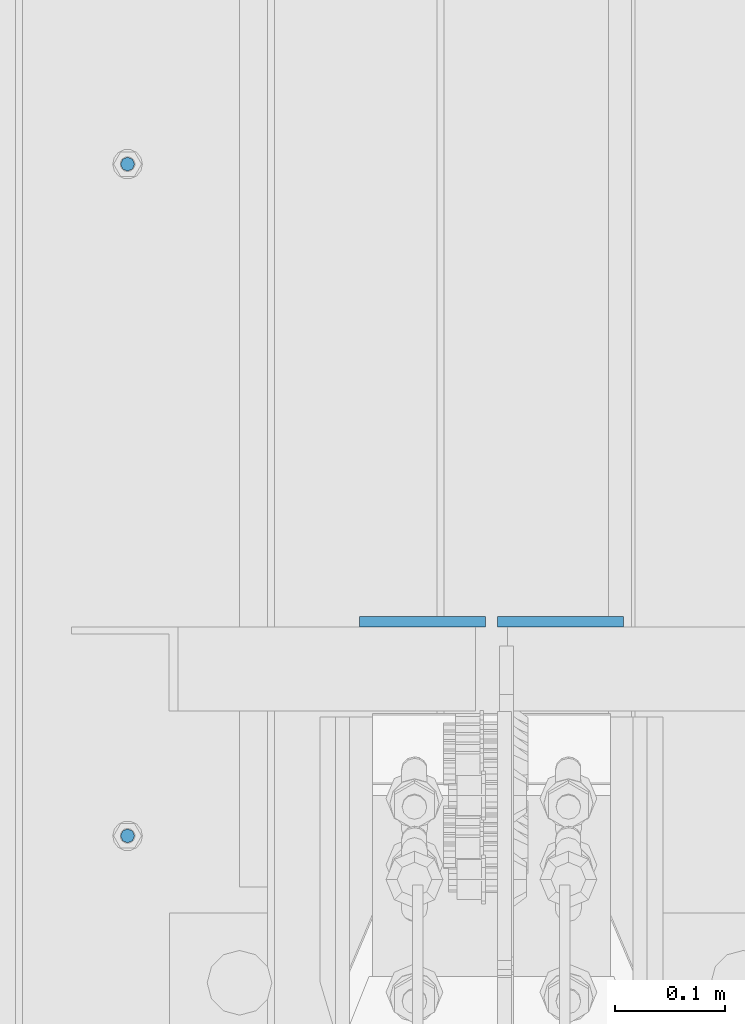
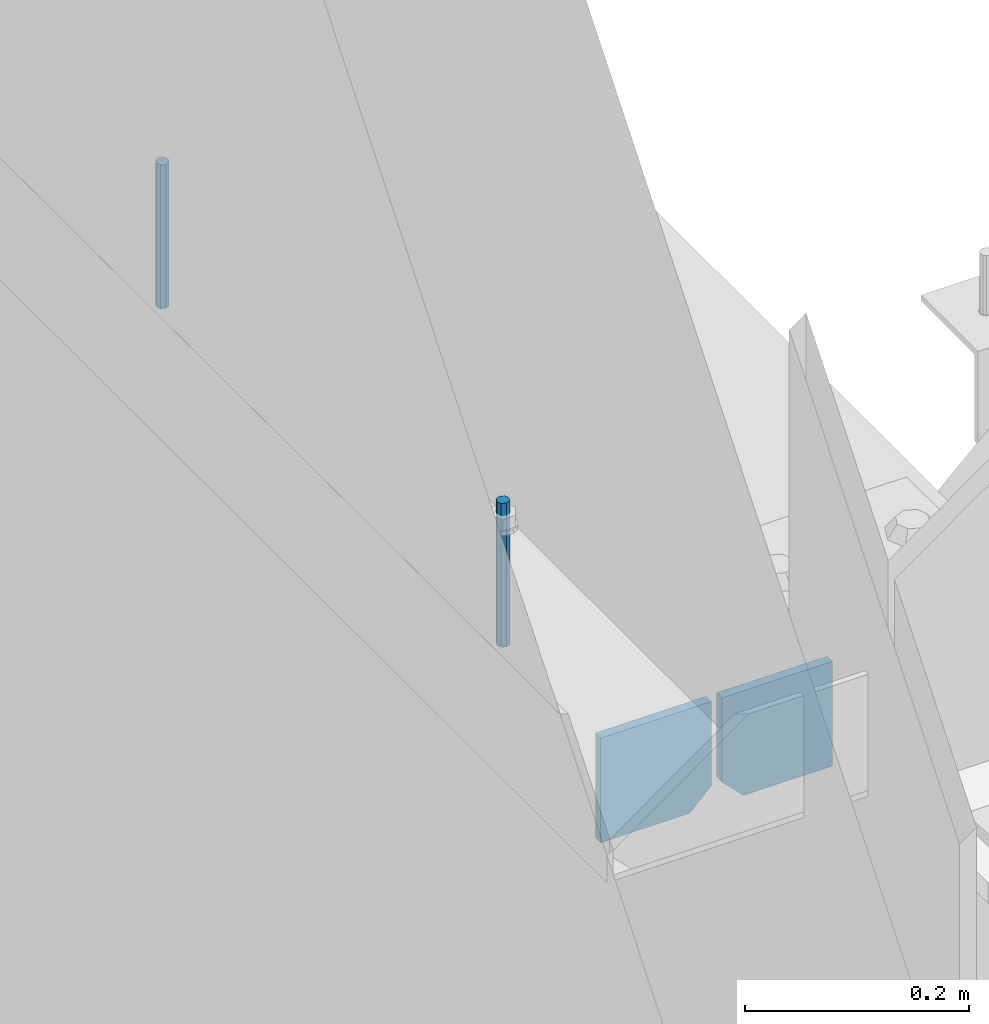
# One storey, part 381 of 1179: 4 columns, 1 element without a shape of its own.
"""IFC2X3 building model written with IfcOpenShell, lengths in millimetres."""

from ifc_helpers import new_model, si_unit, frame, origin_with_axes, place, context, subcontext, project, spatial, faceted_brep, material, type_object, element, aggregate, save


model = new_model("IFC2X3")

# Units and contexts
model_context = context("Model", 3, precision=1e-05, world=origin_with_axes())
body_context = subcontext(model_context, "Body", "Model", "MODEL_VIEW")
ifc_project = project(units=[si_unit("LENGTHUNIT", "METRE", prefix="MILLI"), si_unit("AREAUNIT", "SQUARE_METRE"), si_unit("VOLUMEUNIT", "CUBIC_METRE"), si_unit("MASSUNIT", "GRAM", prefix="KILO"), si_unit("TIMEUNIT", "SECOND"), si_unit("PLANEANGLEUNIT", "RADIAN"), si_unit("SOLIDANGLEUNIT", "STERADIAN"), si_unit("THERMODYNAMICTEMPERATUREUNIT", "DEGREE_CELSIUS"), si_unit("LUMINOUSINTENSITYUNIT", "LUMEN")], contexts=[model_context])

# Site, building, storey
site_placement = place(None, origin_with_axes())
site = spatial("IfcSite", under=ifc_project, at=site_placement, CompositionType="ELEMENT")
building_placement = place(site_placement, origin_with_axes())
building = spatial("IfcBuilding", under=site, at=building_placement, Name="Undefined", CompositionType="ELEMENT")
storey_placement = place(building_placement, origin_with_axes())
storey = spatial("IfcBuildingStorey", under=building, at=storey_placement, Name="Undefined", CompositionType="ELEMENT", Elevation=0.0)

# Assembly, columns
assembly_placement = place(storey_placement, origin_with_axes())
assembly = element("IfcElementAssembly", 1, at=assembly_placement, inside=storey, Name="BEAM", AssemblyPlace="NOTDEFINED", PredefinedType="RIGID_FRAME")
ifc_material_1 = material(Name="STEEL/A36")
column_type_1 = type_object("IfcColumnType", PredefinedType="NOTDEFINED")
column_1_placement = place(assembly_placement, frame((494.506249999995, 5992.02249128227, 3702.05), z_axis=(-1.0, 0.0, 0.0), x_axis=(0.0, 0.0, 1.0)))
column_1 = element("IfcColumn", 2, at=column_1_placement, type_object=column_type_1, material=ifc_material_1, Name="PLATE", context=body_context, shape_type="Brep", body=[
    faceted_brep([(22.2250000000004, 4.76250000000073, 57.1500000000015), (0.0, 4.76250000000073, 34.9249999999993), (0.0, -4.76250000000073, 34.9249999999993), (22.2250000000004, -4.76250000000073, 57.1500000000015), (114.300000000001, 4.76250000000073, 57.1500000000015), (114.300000000001, 4.76250000000073, -57.1500000000015), (0.0, 4.76250000000073, -57.1500000000015), (114.300000000001, -4.76250000000073, 57.1500000000015), (0.0, -4.76250000000073, -57.1500000000015), (114.300000000001, -4.76250000000073, -57.1500000000015)], [[[0, 1, 2, 3]], [[4, 5, 6, 1, 0]], [[7, 4, 0, 3]], [[8, 9, 7, 3, 2]], [[8, 6, 5, 9]], [[7, 9, 5, 4]], [[6, 8, 2, 1]]]),
])
column_2_placement = place(assembly_placement, frame((369.09375, 5992.02249128227, 3702.05), z_axis=(1.0, 0.0, 0.0), x_axis=(0.0, 0.0, 1.0)))
column_2 = element("IfcColumn", 3, at=column_2_placement, type_object=column_type_1, material=ifc_material_1, Name="PLATE", context=body_context, shape_type="Brep", body=[
    faceted_brep([(22.2250000000004, 4.76250000000073, 57.1500000000015), (0.0, 4.76250000000073, 34.9249999999993), (0.0, -4.76250000000073, 34.9249999999993), (22.2250000000004, -4.76250000000073, 57.1500000000015), (114.300000000001, 4.76250000000073, 57.1500000000015), (114.300000000001, 4.76250000000073, -57.1500000000015), (0.0, 4.76250000000073, -57.1500000000015), (114.300000000001, -4.76250000000073, 57.1500000000015), (0.0, -4.76250000000073, -57.1500000000015), (114.300000000001, -4.76250000000073, -57.1500000000015)], [[[0, 1, 2, 3]], [[4, 5, 6, 1, 0]], [[7, 4, 0, 3]], [[8, 9, 7, 3, 2]], [[8, 6, 5, 9]], [[7, 9, 5, 4]], [[6, 8, 2, 1]]]),
])
ifc_material_2 = material(Name="STEEL/A307")
column_type_2 = type_object("IfcColumnType", PredefinedType="NOTDEFINED")
column_3_placement = place(assembly_placement, frame((101.599999999999, 6407.14975, 4108.45), z_axis=(0.0, 1.0, 0.0), x_axis=(0.0, 0.0, 1.0)))
column_3 = element("IfcColumn", 4, at=column_3_placement, type_object=column_type_2, material=ifc_material_2, Name="THREADED ROD", context=body_context, shape_type="Brep", body=[
    faceted_brep([(0.0, -6.34999999999854, 0.0), (0.0, -4.49012806053361, -4.49012806053452), (157.162499999999, -4.49012806053361, -4.49012806053361), (157.162499999999, -6.34999999999854, 0.0), (0.0, 0.0, -6.34999999999991), (157.162499999999, 0.0, -6.34999999999854), (0.0, 4.49012806053361, -4.49012806053452), (157.162499999999, 4.49012806053361, -4.49012806053361), (0.0, 6.34999999999854, 0.0), (157.162499999999, 6.34999999999854, 0.0), (0.0, 4.49012806053361, 4.49012806053452), (157.162499999999, 4.49012806053361, 4.49012806053361), (0.0, 0.0, 6.34999999999991), (157.162499999999, 0.0, 6.34999999999854), (0.0, -4.49012806053361, 4.49012806053452), (157.162499999999, -4.49012806053361, 4.49012806053361)], [[[0, 1, 2, 3]], [[1, 4, 5, 2]], [[4, 6, 7, 5]], [[6, 8, 9, 7]], [[8, 10, 11, 9]], [[10, 12, 13, 11]], [[12, 14, 15, 13]], [[14, 0, 3, 15]], [[5, 7, 9, 11, 13, 15, 3, 2]], [[14, 12, 10, 8, 6, 4, 1, 0]]]),
])
column_4_placement = place(assembly_placement, frame((101.599999999999, 5797.54975, 4108.45), z_axis=(0.0, 1.0, 0.0), x_axis=(0.0, 0.0, 1.0)))
column_4 = element("IfcColumn", 5, at=column_4_placement, type_object=column_type_2, material=ifc_material_2, Name="THREADED ROD", context=body_context, shape_type="Brep", body=[
    faceted_brep([(0.0, -6.34999999999854, 0.0), (0.0, -4.49012806053361, -4.49012806053452), (157.162499999999, -4.49012806053361, -4.49012806053361), (157.162499999999, -6.34999999999854, 0.0), (0.0, 0.0, -6.34999999999991), (157.162499999999, 0.0, -6.34999999999854), (0.0, 4.49012806053361, -4.49012806053452), (157.162499999999, 4.49012806053361, -4.49012806053361), (0.0, 6.34999999999854, 0.0), (157.162499999999, 6.34999999999854, 0.0), (0.0, 4.49012806053361, 4.49012806053452), (157.162499999999, 4.49012806053361, 4.49012806053361), (0.0, 0.0, 6.34999999999991), (157.162499999999, 0.0, 6.34999999999854), (0.0, -4.49012806053361, 4.49012806053452), (157.162499999999, -4.49012806053361, 4.49012806053361)], [[[0, 1, 2, 3]], [[1, 4, 5, 2]], [[4, 6, 7, 5]], [[6, 8, 9, 7]], [[8, 10, 11, 9]], [[10, 12, 13, 11]], [[12, 14, 15, 13]], [[14, 0, 3, 15]], [[5, 7, 9, 11, 13, 15, 3, 2]], [[14, 12, 10, 8, 6, 4, 1, 0]]]),
])
aggregate(assembly, [column_3, column_4, column_1, column_2])

save(model, "model.ifc")
